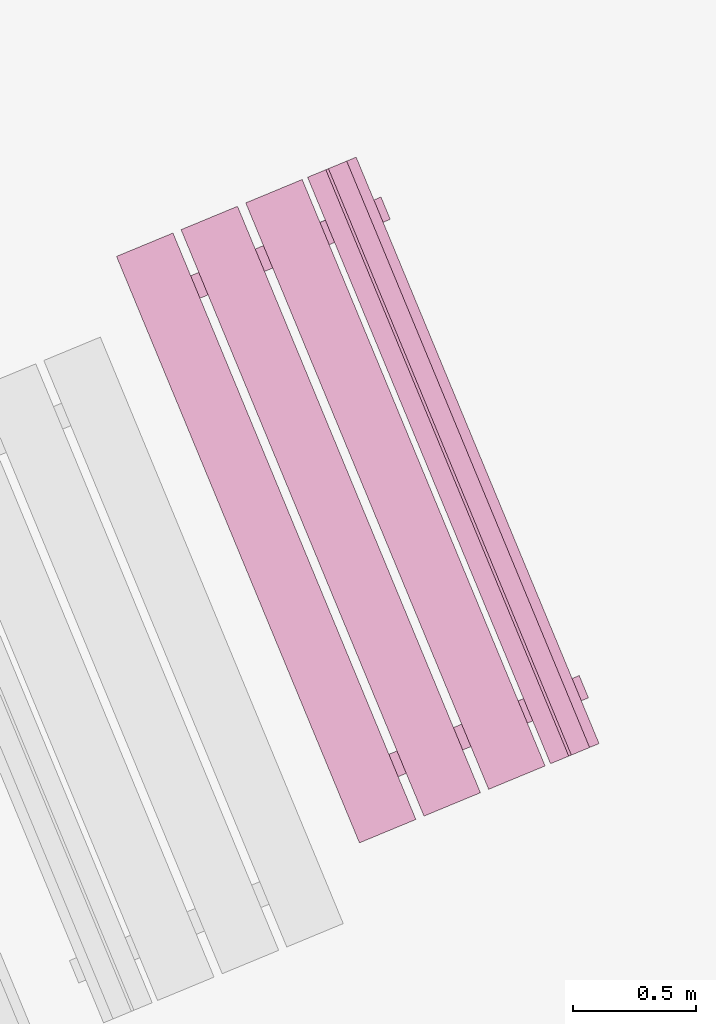
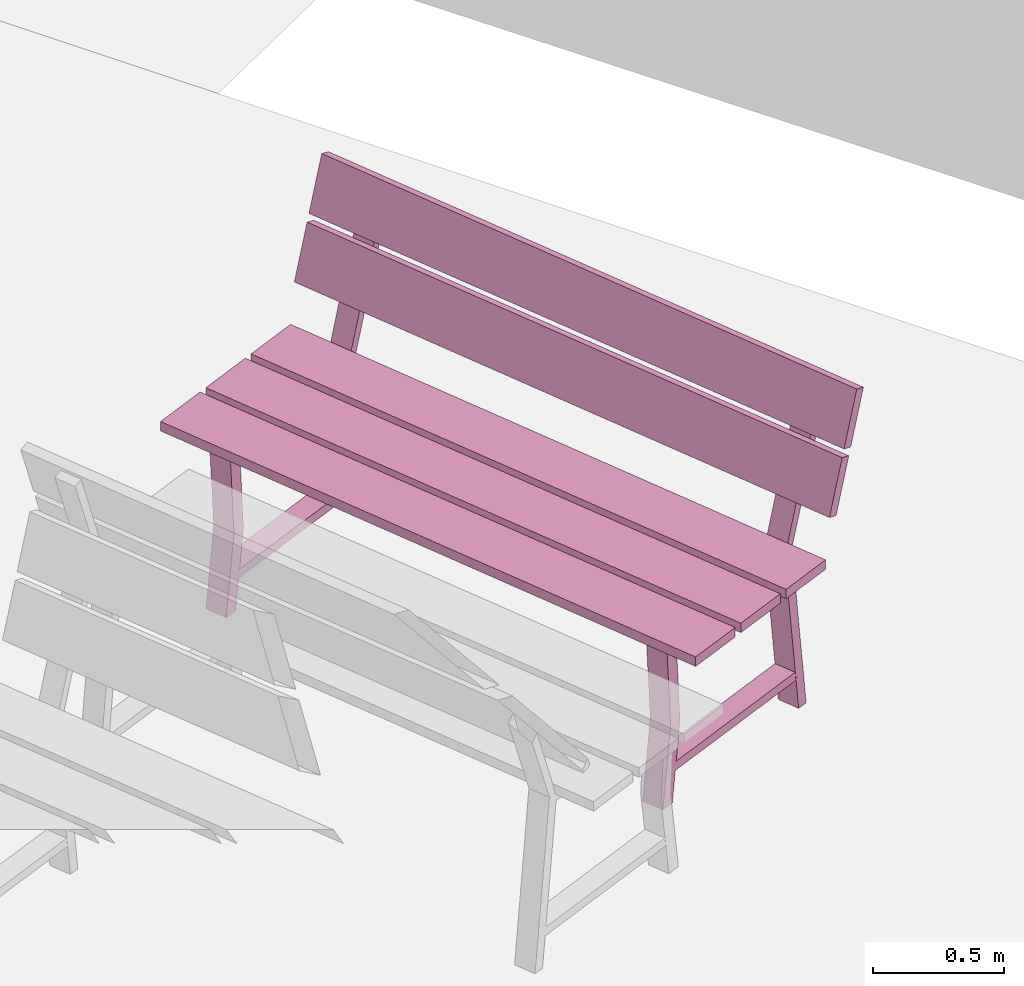
# One storey, part 10 of 200: 1 furnishing.
"""IFC4 building model written with IfcOpenShell, lengths in metres."""

from ifc_helpers import new_model, si_unit, origin_with_axes, place, context, subcontext, project, spatial, triangles, material, element, save


model = new_model("IFC4")

# Units and contexts
model_context = context("Model", 3, precision=1e-05, world=origin_with_axes())
body_context = subcontext(model_context, "Body", "Model", "MODEL_VIEW")
ifc_project = project(units=[si_unit("VOLUMEUNIT", "CUBIC_METRE"), si_unit("LENGTHUNIT", "METRE"), si_unit("AREAUNIT", "SQUARE_METRE")], contexts=[model_context])

# Site, building, storey
site_placement = place(None, origin_with_axes())
site = spatial("IfcSite", under=ifc_project, at=site_placement)
building_placement = place(site_placement, origin_with_axes())
building = spatial("IfcBuilding", under=site, at=building_placement, Name="Building")
storey_placement = place(building_placement, origin_with_axes())
storey = spatial("IfcBuildingStorey", under=building, at=storey_placement, Name="Ground")

# Furnishing
ifc_material = material(Name="bench")
furnishing_placement = place(storey_placement, origin_with_axes())
element("IfcFurnishingElement", 1, at=furnishing_placement, inside=storey, material=ifc_material, Name="cw_instances_bench_32", context=body_context, shape_type="Tessellation", body=[
    triangles([(262.25090067387345, -648.3850149305823, 0.815520754558246), (262.4802739380731, -648.290005413705, 0.815520754558246), (261.49315890687035, -645.9068989177531, 0.815520754558246), (261.2637856426707, -646.0019084346303, 0.815520754558246), (261.2095781780354, -646.2283861335779, 0.36316797911391596), (261.2472129887549, -646.3192446040342, 0.36316797911391596), (261.202080602596, -646.3379390504836, 1.4462435886752271e-07), (261.1644457918765, -646.2470805800272, 1.4462435886752271e-07), (261.1918367932799, -646.3421821752327, 0.36316797911391596), (261.1092180283593, -646.2699566686956, 1.6069373207502523e-07), (261.1468528390788, -646.3608151391519, 1.6069373207502523e-07), (261.15420198256044, -646.2513237047763, 0.36316797911391596), (261.89599047377834, -646.0505121707753, 0.7742224172068448), (261.89599047377834, -646.0505121707753, 0.7742224172068448), (261.9789804173965, -646.0161366105881, 0.0), (261.941345606677, -645.9252781401317, 0.0), (261.941345606677, -645.9252781401317, 0.0), (261.8581711847215, -645.9592083302149, 0.7742224172068448), (261.8566481216644, -646.0668083065965, 0.7346917591163886), (261.89784631351506, -645.943296137313, 1.6069373207502518e-08), (261.9354811242345, -646.0341546077693, 1.6069373207502518e-08), (261.81901331094497, -645.9759498361401, 0.7353345501140619), (261.18730897506384, -646.237610339472, 0.7353346465303011), (261.2246468624832, -646.3285917995862, 0.7346918555326278), (261.16882531175037, -646.3517138429725, 0.7742225618312036), (261.1310060226935, -646.2604100024121, 0.7742225618312036), (261.9885689530513, -648.4936762871876, 0.8155208509744852), (262.21794220240474, -648.3986667764597, 0.815520754558246), (261.230827171202, -646.0155602805078, 0.815520754558246), (261.00145392184857, -646.1105697912355, 0.8155208509744852), (262.51367780933816, -648.2761690771913, 0.815520754558246), (262.7430510586916, -648.1811595664635, 0.8155206581420068), (261.7559360274889, -645.7980530705115, 0.8155206581420068), (261.5265627781354, -645.8930625812393, 0.815520754558246), (262.7650233977477, -648.1720583256293, 0.9999971268416286), (261.85199078931305, -645.7582658854334, 1.2349312667190762), (261.777908366545, -645.7889518296774, 0.9999971268416286), (262.8391058205158, -648.1413723813854, 1.2349312667190762), (262.84979507416676, -648.1369447475515, 1.2691590637898031), (261.93676243603977, -645.7231523196546, 1.5040931072510113), (261.86268004296403, -645.7538382515995, 1.2691590637898031), (262.9238774672425, -648.1062588156065, 1.5040931072510113), (262.07623593246007, -645.8692307693304, 1.4584561837579435), (262.11387078007647, -645.9600893288638, 1.4584561837579435), (261.89599047377834, -646.0505121707753, 0.7742224172068448), (261.8581711847215, -645.9592083302149, 0.7742224172068448), (261.8228733286929, -645.9743509644379, 0.7739010297426947), (261.8609535095164, -646.065024956557, 0.7739010297426947), (262.0786853690106, -645.974663603325, 1.4724364581016047), (262.0406051512902, -645.883989522129, 1.4724364581016047), (261.8163599487585, -645.7730246628299, 0.9858560302109066), (261.89029392472264, -645.7424002072654, 1.2207902665045935), (262.8034749799612, -648.1561311587818, 0.9858560302109066), (262.8774089559254, -648.1255067032173, 1.2207902665045935), (261.9011316103314, -645.7379110909014, 1.2550180635753205), (261.97521401825327, -645.7072251528069, 1.4899522998690073), (262.8882466415341, -648.1210175868534, 1.2550180635753205), (262.962329049456, -648.0903316487589, 1.4899522998690073), (262.01497595894335, -648.1727883793512, 0.36316797911391596), (262.05261076966286, -648.2636468498075, 0.36316797911391596), (262.007478383504, -648.2823412962567, 1.4462435886752271e-07), (261.96984357278455, -648.1914828258004, 1.4462435886752271e-07), (261.99723457418787, -648.2865844210058, 0.36316797911391596), (261.9146158092673, -648.2143589144688, 1.6069373207502523e-07), (261.9522506199868, -648.3052173849252, 1.6069373207502523e-07), (261.9595997634684, -648.1957259505496, 0.36316797911391596), (262.7013882546863, -647.9949144165485, 0.7742224172068448), (262.7013882546863, -647.9949144165485, 0.7742224172068448), (262.78437819830447, -647.9605388563613, 0.0), (262.74674338758496, -647.869680385905, 0.0), (262.74674338758496, -647.869680385905, 0.0), (262.6636304358605, -647.9037589782536, 0.7742224172068448), (262.6620459025724, -648.0112105523697, 0.7346917591163886), (262.70324409442304, -647.8876983830863, 1.6069373207502518e-08), (262.7408789051425, -647.9785568535426, 1.6069373207502518e-08), (262.62441109185295, -647.9203520819134, 0.7353345501140619), (261.9927067559718, -648.1820125852453, 0.7353346465303011), (262.0300446433912, -648.2729940453595, 0.7346918555326278), (261.97422309265835, -648.2961160887457, 0.7742225618312036), (261.9364652738325, -648.2049606504507, 0.7742225618312036), (262.881695220496, -647.8137815064462, 1.4584561837579435), (262.91926856713394, -647.9044915894832, 1.4584561837579435), (262.7013882546863, -647.9949144165485, 0.7742224172068448), (262.6636304358605, -647.9037589782536, 0.7742224172068448), (262.62827110960086, -647.9187532102112, 0.7739010297426947), (262.66635129042436, -648.0094272023301, 0.7739010297426947), (262.8840831560681, -647.9190658639443, 1.4724364581016047), (262.8460644393261, -647.8285402592446, 1.4724364581016047), (262.4802739380731, -648.290005413705, 0.815520754558246), (261.49315890687035, -645.9068989177531, 0.7716513657017641), (261.49315890687035, -645.9068989177531, 0.815520754558246), (262.4802739380731, -648.290005413705, 0.7716513657017641), (262.25090067387345, -648.3850149305823, 0.7716514139098837), (261.2637856426707, -646.0019084346303, 0.815520754558246), (261.2637856426707, -646.0019084346303, 0.7716514139098837), (262.25090067387345, -648.3850149305823, 0.815520754558246), (261.1644457918765, -646.2470805800272, 1.4462435886752271e-07), (261.15420198256044, -646.2513237047763, 0.36316797911391596), (261.2095781780354, -646.2283861335779, 0.36316797911391596), (261.1092180283593, -646.2699566686956, 1.6069373207502523e-07), (261.81901331094497, -645.9759498361401, 0.7353345501140619), (261.8581711847215, -645.9592083302149, 0.7742224172068448), (261.941345606677, -645.9252781401317, 0.0), (261.89784631351506, -645.943296137313, 1.6069373207502518e-08), (261.1918367932799, -646.3421821752327, 0.36316797911391596), (261.2472129887549, -646.3192446040342, 0.36316797911391596), (261.2246468624832, -646.3285917995862, 0.7346918555326278), (261.16882531175037, -646.3517138429725, 0.7742225618312036), (261.89599047377834, -646.0505121707753, 0.7742224172068448), (261.8566481216644, -646.0668083065965, 0.7346917591163886), (261.9789804173965, -646.0161366105881, 0.0), (261.9354811242345, -646.0341546077693, 1.6069373207502518e-08), (261.18730897506384, -646.237610339472, 0.7353346465303011), (261.1310060226935, -646.2604100024121, 0.7742225618312036), (261.202080602596, -646.3379390504836, 1.4462435886752271e-07), (261.1468528390788, -646.3608151391519, 1.6069373207502523e-07), (262.07623593246007, -645.8692307693304, 1.4584561837579435), (262.0786853690106, -645.974663603325, 1.4724364581016047), (262.11387078007647, -645.9600893288638, 1.4584561837579435), (262.0406051512902, -645.883989522129, 1.4724364581016047), (261.9246583746195, -646.0374200019464, 0.13996424063734697), (261.9246583746195, -646.0374200019464, 0.17949489872780322), (261.20937015944304, -646.3337020816782, 0.13996438526170585), (261.20892475964666, -646.3338865723146, 0.17949504335216207), (261.8877614772495, -645.9483430119062, 0.17949489872780322), (261.88788448535587, -645.9486399797448, 0.1406070155656471), (261.17289317863333, -646.2447990759682, 0.14060716019000596), (261.17202786227665, -646.2448095822743, 0.17949504335216207), (262.21794220240474, -648.3986667764597, 0.815520754558246), (261.230827171202, -646.0155602805078, 0.7716514139098837), (261.230827171202, -646.0155602805078, 0.815520754558246), (262.21794220240474, -648.3986667764597, 0.7716514139098837), (261.9885689530513, -648.4936762871876, 0.7716514621180032), (261.00145392184857, -646.1105697912355, 0.8155208509744852), (261.00145392184857, -646.1105697912355, 0.7716514621180032), (261.9885689530513, -648.4936762871876, 0.8155208509744852), (262.7430510586916, -648.1811595664635, 0.8155206581420068), (261.7559360274889, -645.7980530705115, 0.7716513174936444), (261.7559360274889, -645.7980530705115, 0.8155206581420068), (262.7430510586916, -648.1811595664635, 0.7716513174936444), (262.51367779449197, -648.2761690833407, 0.7716513657017641), (261.5265627781354, -645.8930625812393, 0.815520754558246), (261.5265627632893, -645.8930625873887, 0.7716513657017641), (262.51367780933816, -648.2761690771913, 0.815520754558246), (261.89029392472264, -645.7424002072654, 1.2207902665045935), (262.8391058205158, -648.1413723813854, 1.2349312667190762), (262.8774089559254, -648.1255067032173, 1.2207902665045935), (261.85199078931305, -645.7582658854334, 1.2349312667190762), (262.8034749799612, -648.1561311587818, 0.9858560302109066), (261.777908366545, -645.7889518296774, 0.9999971268416286), (261.8163599487585, -645.7730246628299, 0.9858560302109066), (262.7650233977477, -648.1720583256293, 0.9999971268416286), (261.97521401825327, -645.7072251528069, 1.4899522998690073), (262.9238774672425, -648.1062588156065, 1.5040931072510113), (262.962329049456, -648.0903316487589, 1.4899522998690073), (261.93676243603977, -645.7231523196546, 1.5040931072510113), (262.8882466415341, -648.1210175868534, 1.2550180635753205), (261.86268004296403, -645.7538382515995, 1.2691590637898031), (261.9011316103314, -645.7379110909014, 1.2550180635753205), (262.84979507416676, -648.1369447475515, 1.2691590637898031), (261.96984357278455, -648.1914828258004, 1.4462435886752271e-07), (261.9595997634684, -648.1957259505496, 0.36316797911391596), (262.01497595894335, -648.1727883793512, 0.36316797911391596), (261.9146158092673, -648.2143589144688, 1.6069373207502523e-07), (262.62441109185295, -647.9203520819134, 0.7353345501140619), (262.6636304358605, -647.9037589782536, 0.7742224172068448), (262.74674338758496, -647.869680385905, 0.0), (262.70324409442304, -647.8876983830863, 1.6069373207502518e-08), (261.99723457418787, -648.2865844210058, 0.36316797911391596), (262.05261076966286, -648.2636468498075, 0.36316797911391596), (262.0300446433912, -648.2729940453595, 0.7346918555326278), (261.97422309265835, -648.2961160887457, 0.7742225618312036), (262.7013882546863, -647.9949144165485, 0.7742224172068448), (262.6620459025724, -648.0112105523697, 0.7346917591163886), (262.78437819830447, -647.9605388563613, 0.0), (262.7408789051425, -647.9785568535426, 1.6069373207502518e-08), (261.9927067559718, -648.1820125852453, 0.7353346465303011), (261.9364652738325, -648.2049606504507, 0.7742225618312036), (262.007478383504, -648.2823412962567, 1.4462435886752271e-07), (261.9522506199868, -648.3052173849252, 1.6069373207502523e-07), (262.881695220496, -647.8137815064462, 1.4584561837579435), (262.8840831560681, -647.9190658639443, 1.4724364581016047), (262.91926856713394, -647.9044915894832, 1.4584561837579435), (262.8460644393261, -647.8285402592446, 1.4724364581016047), (262.7301176626554, -647.981970739062, 0.13996424063734697), (262.7301176626554, -647.981970739062, 0.17949489872780322), (262.0148294474789, -648.2782528187938, 0.13996438526170585), (262.01438404768254, -648.2784373094302, 0.17949504335216207), (262.6931592581575, -647.8927452576795, 0.17949489872780322), (262.69334373649485, -647.8931906277835, 0.1406070155656471), (261.9783524297723, -648.1893497240069, 0.14060716019000596), (261.97742564318463, -648.1892118280476, 0.17949504335216207), (262.25090067387345, -648.3850149305823, 0.815520754558246), (262.4802739380731, -648.290005413705, 0.7716513657017641), (262.4802739380731, -648.290005413705, 0.815520754558246), (262.25090067387345, -648.3850149305823, 0.7716514139098837), (261.49315890687035, -645.9068989177531, 0.815520754558246), (261.49315890687035, -645.9068989177531, 0.7716513657017641), (261.2637856426707, -646.0019084346303, 0.7716514139098837), (261.2637856426707, -646.0019084346303, 0.815520754558246), (261.9885689530513, -648.4936762871876, 0.8155208509744852), (262.21794220240474, -648.3986667764597, 0.7716514139098837), (262.21794220240474, -648.3986667764597, 0.815520754558246), (261.9885689530513, -648.4936762871876, 0.7716514621180032), (261.230827171202, -646.0155602805078, 0.815520754558246), (261.230827171202, -646.0155602805078, 0.7716514139098837), (261.00145392184857, -646.1105697912355, 0.7716514621180032), (261.00145392184857, -646.1105697912355, 0.8155208509744852), (262.51367780933816, -648.2761690771913, 0.815520754558246), (262.7430510586916, -648.1811595664635, 0.7716513174936444), (262.7430510586916, -648.1811595664635, 0.8155206581420068), (262.51367779449197, -648.2761690833407, 0.7716513657017641), (261.7559360274889, -645.7980530705115, 0.8155206581420068), (261.7559360274889, -645.7980530705115, 0.7716513174936444), (261.5265627632893, -645.8930625873887, 0.7716513657017641), (261.5265627781354, -645.8930625812393, 0.815520754558246), (262.8034749799612, -648.1561311587818, 0.9858560302109066), (262.8774089559254, -648.1255067032173, 1.2207902665045935), (262.8391058205158, -648.1413723813854, 1.2349312667190762), (262.7650233977477, -648.1720583256293, 0.9999971268416286), (261.85199078931305, -645.7582658854334, 1.2349312667190762), (261.8163599487585, -645.7730246628299, 0.9858560302109066), (261.777908366545, -645.7889518296774, 0.9999971268416286), (261.89029392472264, -645.7424002072654, 1.2207902665045935), (262.8882466415341, -648.1210175868534, 1.2550180635753205), (262.962329049456, -648.0903316487589, 1.4899522998690073), (262.9238774672425, -648.1062588156065, 1.5040931072510113), (262.84979507416676, -648.1369447475515, 1.2691590637898031), (261.93676243603977, -645.7231523196546, 1.5040931072510113), (261.9011316103314, -645.7379110909014, 1.2550180635753205), (261.86268004296403, -645.7538382515995, 1.2691590637898031), (261.97521401825327, -645.7072251528069, 1.4899522998690073), (261.8609535095164, -646.065024956557, 0.7739010297426947), (262.0786853690106, -645.974663603325, 1.4724364581016047), (262.11387078007647, -645.9600893288638, 1.4584561837579435), (261.8581711847215, -645.9592083302149, 0.7742224172068448), (261.8228733286929, -645.9743509644379, 0.7739010297426947), (262.0406051512902, -645.883989522129, 1.4724364581016047), (262.07623593246007, -645.8692307693304, 1.4584561837579435), (262.66635129042436, -648.0094272023301, 0.7739010297426947), (262.8840831560681, -647.9190658639443, 1.4724364581016047), (262.91926856713394, -647.9044915894832, 1.4584561837579435), (262.6636304358605, -647.9037589782536, 0.7742224172068448), (262.62827110960086, -647.9187532102112, 0.7739010297426947), (262.8460644393261, -647.8285402592446, 1.4724364581016047), (262.881695220496, -647.8137815064462, 1.4584561837579435), (261.89599047377834, -646.0505121707753, 0.7742224172068448), (261.8581711847215, -645.9592083302149, 0.7742224172068448), (261.16882531175037, -646.3517138429725, 0.7742225618312036), (261.1310060226935, -646.2604100024121, 0.7742225618312036), (261.9246583746195, -646.0374200019464, 0.17949489872780322), (261.8877614772495, -645.9483430119062, 0.17949489872780322), (261.20892475964666, -646.3338865723146, 0.17949504335216207), (261.17202786227665, -646.2448095822743, 0.17949504335216207), (262.7013882546863, -647.9949144165485, 0.7742224172068448), (262.6636304358605, -647.9037589782536, 0.7742224172068448), (261.97422309265835, -648.2961160887457, 0.7742225618312036), (261.9364652738325, -648.2049606504507, 0.7742225618312036), (262.7301176626554, -647.981970739062, 0.17949489872780322), (262.6931592581575, -647.8927452576795, 0.17949489872780322), (262.01438404768254, -648.2784373094302, 0.17949504335216207), (261.97742564318463, -648.1892118280476, 0.17949504335216207)], [[1, 2, 3], [3, 4, 1], [5, 6, 7], [7, 8, 5], [9, 10, 11], [10, 9, 12], [14, 15, 16], [17, 18, 13], [19, 20, 21], [20, 19, 22], [23, 24, 5], [24, 6, 5], [12, 9, 25], [25, 26, 12], [27, 28, 29], [29, 30, 27], [31, 32, 33], [33, 34, 31], [35, 36, 37], [35, 38, 36], [39, 40, 41], [39, 42, 40], [43, 44, 45], [45, 46, 43], [47, 48, 49], [49, 50, 47], [51, 52, 53], [54, 53, 52], [55, 56, 57], [58, 57, 56], [59, 60, 61], [61, 62, 59], [63, 64, 65], [64, 63, 66], [68, 69, 71], [70, 72, 67], [73, 74, 75], [74, 73, 76], [77, 78, 59], [78, 60, 59], [66, 63, 79], [79, 80, 66], [81, 82, 83], [83, 84, 81], [85, 86, 87], [87, 88, 85], [89, 90, 91], [89, 92, 90], [93, 94, 95], [93, 96, 94], [97, 98, 99], [97, 100, 98], [101, 102, 103], [103, 104, 101], [105, 106, 107], [107, 108, 105], [109, 110, 111], [110, 112, 111], [108, 107, 109], [107, 110, 109], [113, 99, 98], [98, 114, 113], [115, 106, 105], [105, 116, 115], [117, 118, 119], [117, 120, 118], [102, 101, 113], [113, 114, 102], [121, 122, 123], [122, 124, 123], [125, 126, 127], [127, 128, 125], [129, 130, 131], [129, 132, 130], [133, 134, 135], [133, 136, 134], [137, 138, 139], [137, 140, 138], [141, 142, 143], [141, 144, 142], [145, 146, 147], [145, 148, 146], [149, 150, 151], [149, 152, 150], [153, 154, 155], [153, 156, 154], [157, 158, 159], [157, 160, 158], [161, 162, 163], [161, 164, 162], [165, 166, 167], [167, 168, 165], [169, 170, 171], [171, 172, 169], [173, 174, 175], [174, 176, 175], [172, 171, 173], [171, 174, 173], [177, 163, 162], [162, 178, 177], [179, 170, 169], [169, 180, 179], [181, 182, 183], [181, 184, 182], [166, 165, 177], [177, 178, 166], [185, 186, 187], [186, 188, 187], [189, 190, 191], [191, 192, 189], [193, 194, 195], [194, 193, 196], [197, 198, 199], [199, 200, 197], [201, 202, 203], [202, 201, 204], [205, 206, 207], [207, 208, 205], [209, 210, 211], [210, 209, 212], [213, 214, 215], [215, 216, 213], [217, 218, 219], [219, 220, 217], [221, 222, 223], [222, 221, 224], [225, 226, 227], [227, 228, 225], [229, 230, 231], [230, 229, 232], [233, 109, 234], [109, 235, 234], [236, 237, 238], [238, 239, 236], [240, 173, 241], [173, 242, 241], [243, 244, 245], [245, 246, 243], [247, 248, 249], [248, 250, 249], [251, 252, 253], [252, 254, 253], [255, 256, 257], [256, 258, 257], [259, 260, 261], [260, 262, 261]], closed=True),
])

save(model, "model.ifc")
